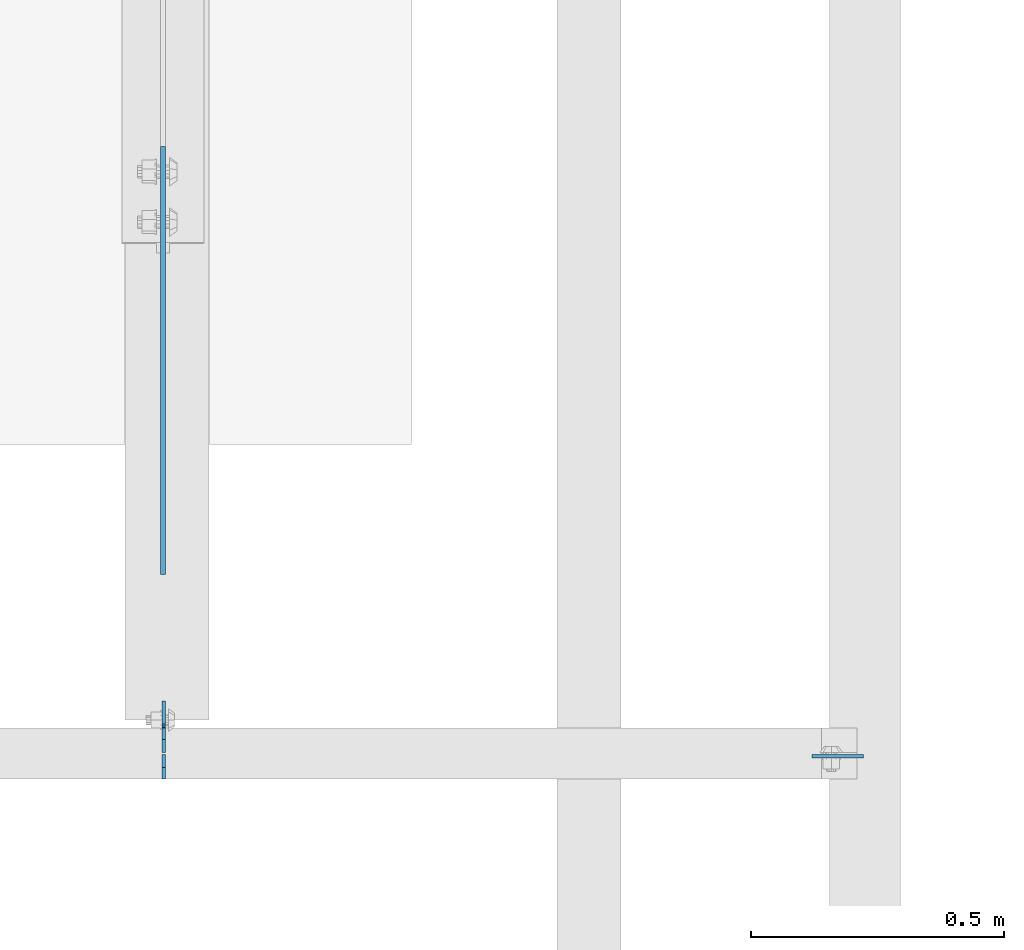
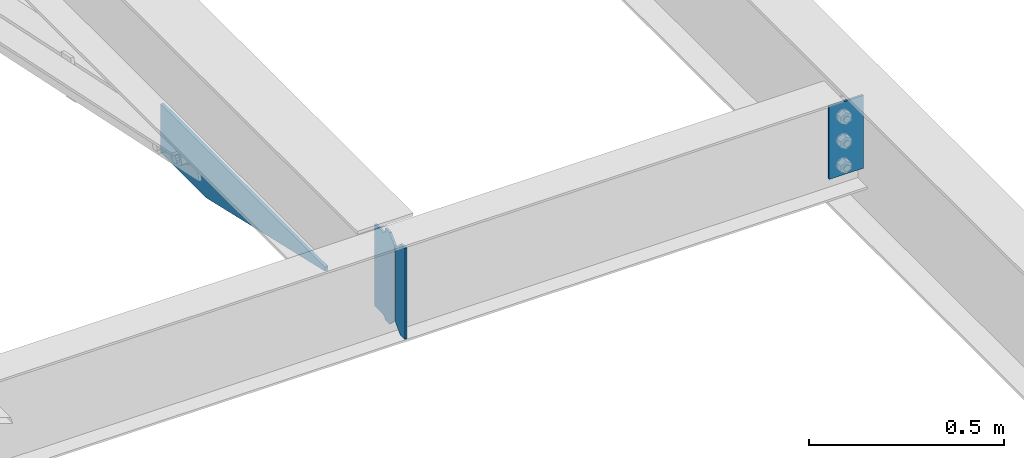
# One storey, part 1607 of 1763: 4 plates, 3 elements without a shape of their own.
"""IFC2X3 building model written with IfcOpenShell, lengths in millimetres."""

import ifcopenshell
import ifcopenshell.guid

model = None  # the IFC model being written
_history = None  # IfcOwnerHistory: only IFC2X3 demands one
_inside = {}  # id of a spatial element -> (the spatial element, [elements in it])
_under = {}  # id of a project, library or spatial element -> (it, [spatial elements below it])
_declared = {}  # id of a project -> (the project, [libraries it declares])
_typed = {}  # id of a type object -> (the type object, [elements of that type])
_made_of = {}  # id of a material, layer set ... -> (it, [elements and type objects made of it])


def new_model(schema):
    """Start an empty IFC model of exactly this schema.

    Asked for "IFC4X3", IfcOpenShell would pick the latest addendum, in which some entities
    have other attributes; the version numbers below select the first issue.
    IFC2X3 requires an IfcOwnerHistory on every rooted entity: one is made here for all.
    """
    global model, _history
    if schema == "IFC4X3":
        model = ifcopenshell.file(schema_version=(4, 3, 0, 0))
    else:
        model = ifcopenshell.file(schema=schema)
    _inside.clear()
    _under.clear()
    _declared.clear()
    _typed.clear()
    _made_of.clear()
    _history = None
    if model.schema == "IFC2X3":
        org = make("IfcOrganization", Name="unknown")
        user = make(
            "IfcPersonAndOrganization",
            ThePerson=make("IfcPerson", FamilyName="unknown"),
            TheOrganization=org,
        )
        app = make(
            "IfcApplication",
            ApplicationDeveloper=org,
            Version="unknown",
            ApplicationFullName="unknown",
            ApplicationIdentifier="unknown",
        )
        _history = make(
            "IfcOwnerHistory",
            OwningUser=user,
            OwningApplication=app,
            ChangeAction="ADDED",
            CreationDate=0,
        )
    return model


def make(cls, **values):
    """One entity of the class cls with the attributes given. An attribute that is None is left unset."""
    return model.create_entity(
        cls, **{name: value for name, value in values.items() if value is not None}
    )


def rooted(cls, **values):
    """An entity with a GlobalId (a new one), such as an element, a storey or a relation."""
    return make(cls, GlobalId=ifcopenshell.guid.new(), OwnerHistory=_history, **values)


def si_unit(unit_type, name, prefix=None):
    """IfcSIUnit, for example si_unit("LENGTHUNIT", "METRE", prefix="MILLI")."""
    return make("IfcSIUnit", UnitType=unit_type, Prefix=prefix, Name=name)


def assignment(units):
    """IfcUnitAssignment: the units of a project."""
    return None if units is None else make("IfcUnitAssignment", Units=units)


def point(xyz):
    """IfcCartesianPoint."""
    return None if xyz is None else make("IfcCartesianPoint", Coordinates=xyz)


def direction(xyz):
    """IfcDirection."""
    return None if xyz is None else make("IfcDirection", DirectionRatios=xyz)


def frame(location, z_axis=None, x_axis=None):
    """IfcAxis2Placement3D, a coordinate frame: its origin and axes. An axis left out is left unset."""
    return make(
        "IfcAxis2Placement3D",
        Location=point(location),
        Axis=direction(z_axis),
        RefDirection=direction(x_axis),
    )


def origin_with_axes():
    """The frame at (0, 0, 0) with the z axis (0, 0, 1) and the x axis (1, 0, 0) written out."""
    return frame((0.0, 0.0, 0.0), z_axis=(0.0, 0.0, 1.0), x_axis=(1.0, 0.0, 0.0))


def place(relative_to, where):
    """IfcLocalPlacement: puts the frame where relative to a parent placement (None: the world)."""
    return make(
        "IfcLocalPlacement", PlacementRelTo=relative_to, RelativePlacement=where
    )


def context(
    kind, dimensions, precision=None, world=None, true_north=None, identifier=None
):
    """IfcGeometricRepresentationContext, for example the 3D "Model" context."""
    return make(
        "IfcGeometricRepresentationContext",
        ContextIdentifier=identifier,
        ContextType=kind,
        CoordinateSpaceDimension=dimensions,
        Precision=precision,
        WorldCoordinateSystem=world,
        TrueNorth=true_north,
    )


def subcontext(parent, identifier, kind, view, scale=None):
    """IfcGeometricRepresentationSubContext, for example "Body" below "Model"."""
    return make(
        "IfcGeometricRepresentationSubContext",
        ContextIdentifier=identifier,
        ContextType=kind,
        ParentContext=parent,
        TargetScale=scale,
        TargetView=view,
    )


def project(units=None, contexts=None):
    """IfcProject with its units and contexts."""
    return rooted(
        "IfcProject",
        Name="project",
        RepresentationContexts=contexts,
        UnitsInContext=assignment(units),
    )


def spatial(cls, under=None, at=None, **own):
    """A site, building, storey or space (cls), placed at a placement, below another one or the project."""
    s = rooted(cls, ObjectPlacement=at, **own)
    if under is not None:
        _under.setdefault(under.id(), (under, []))[1].append(s)
    return s


def faces_of(points, faces, orient=None, outer=None):
    """IfcFace entities. A face is a list of loops; a loop is a list of indices into points, from 0.

    orient and outer hold one flag for each loop. By default every Orientation is true, the
    first loop of a face is its IfcFaceOuterBound and the others are IfcFaceBound.
    """
    made = []
    for i, loops in enumerate(faces):
        bounds = []
        for j, loop in enumerate(loops):
            is_outer = j == 0 if outer is None else outer[i][j]
            bounds.append(
                make(
                    "IfcFaceOuterBound" if is_outer else "IfcFaceBound",
                    Bound=make("IfcPolyLoop", Polygon=[points[k] for k in loop]),
                    Orientation=True if orient is None else orient[i][j],
                )
            )
        made.append(make("IfcFace", Bounds=bounds))
    return made


def faceted_brep(points, faces, orient=None, outer=None, voids=None):
    """IfcFacetedBrep: a solid bounded by flat faces; with voids (closed shells), ...WithVoids."""
    shared = [point(p) for p in points]
    hull = make("IfcClosedShell", CfsFaces=faces_of(shared, faces, orient, outer))
    if voids is None:
        return make("IfcFacetedBrep", Outer=hull)
    return make(
        "IfcFacetedBrepWithVoids",
        Outer=hull,
        Voids=[
            make(cls, CfsFaces=faces_of(shared, fs, o, b)) for cls, fs, o, b in voids
        ],
    )


def shape(context_of_items, identifier, shape_type, items):
    """IfcShapeRepresentation: the items that make up one representation, for example the "Body"."""
    return make(
        "IfcShapeRepresentation",
        ContextOfItems=context_of_items,
        RepresentationIdentifier=identifier,
        RepresentationType=shape_type,
        Items=items,
    )


def material(Name=None, Category=None):
    """IfcMaterial."""
    return make("IfcMaterial", Name=Name, Category=Category)


def made_of(thing, what):
    """Note that an element or type object is made of a material, layer set ...; save() writes the relation."""
    if what is not None:
        _made_of.setdefault(what.id(), (what, []))[1].append(thing)
    return thing


def type_object(cls, material=None, **own):
    """A type object (cls), such as IfcWallType, which elements share."""
    return made_of(rooted(cls, **own), material)


def element(
    cls,
    number,
    at=None,
    inside=None,
    cuts=None,
    type_object=None,
    material=None,
    context=None,
    identifier="Body",
    shape_type=None,
    held_by="IfcProductDefinitionShape",
    body=None,
    shapes=None,
    **own,
):
    """One element of the class cls, such as IfcWall. Its Tag is "e" and its number.

    at: its placement. inside: the storey or other place that contains it. cuts: it is an
    opening in that element (IfcRelVoidsElement). A single representation is given by context,
    identifier, shape_type and body (its items); several are given by shapes. held_by: the class
    of the entity that holds the representations. save() writes the other relations.
    """
    e = rooted(cls, Tag="e%d" % number, ObjectPlacement=at, **own)
    if body is not None:
        shapes = [shape(context, identifier, shape_type, body)]
    if shapes is not None:
        e.Representation = make(held_by, Representations=shapes)
    if inside is not None:
        _inside.setdefault(inside.id(), (inside, []))[1].append(e)
    if cuts is not None:
        rooted(
            "IfcRelVoidsElement", RelatingBuildingElement=cuts, RelatedOpeningElement=e
        )
    if type_object is not None:
        _typed.setdefault(type_object.id(), (type_object, []))[1].append(e)
    return made_of(e, material)


def aggregate(whole, parts):
    """IfcRelAggregates: a whole, such as a stair, and the parts it consists of."""
    return rooted("IfcRelAggregates", RelatingObject=whole, RelatedObjects=parts)


def save(model, path):
    """Write the relations noted so far, then the file.

    IfcRelAggregates (storeys below a building ...), IfcRelContainedInSpatialStructure (elements
    in a storey), IfcRelDefinesByType, IfcRelAssociatesMaterial and IfcRelDeclares: one each for
    every whole, place, type object, material and project.
    """
    for whole, parts in _under.values():
        aggregate(whole, parts)
    for where, things in _inside.values():
        rooted(
            "IfcRelContainedInSpatialStructure",
            RelatedElements=things,
            RelatingStructure=where,
        )
    for kind, things in _typed.values():
        rooted("IfcRelDefinesByType", RelatedObjects=things, RelatingType=kind)
    for what, things in _made_of.values():
        rooted("IfcRelAssociatesMaterial", RelatedObjects=things, RelatingMaterial=what)
    for by, libraries in _declared.values():
        rooted("IfcRelDeclares", RelatingContext=by, RelatedDefinitions=libraries)
    model.write(path)


model = new_model("IFC2X3")

# Units and contexts
model_context = context("Model", 3, precision=1e-05, world=origin_with_axes())
body_context = subcontext(model_context, "Body", "Model", "MODEL_VIEW")
ifc_project = project(units=[si_unit("LENGTHUNIT", "METRE", prefix="MILLI"), si_unit("AREAUNIT", "SQUARE_METRE"), si_unit("VOLUMEUNIT", "CUBIC_METRE"), si_unit("MASSUNIT", "GRAM", prefix="KILO"), si_unit("TIMEUNIT", "SECOND"), si_unit("PLANEANGLEUNIT", "RADIAN"), si_unit("SOLIDANGLEUNIT", "STERADIAN"), si_unit("THERMODYNAMICTEMPERATUREUNIT", "DEGREE_CELSIUS"), si_unit("LUMINOUSINTENSITYUNIT", "LUMEN")], contexts=[model_context])

# Site, building, storey
site_placement = place(None, origin_with_axes())
site = spatial("IfcSite", under=ifc_project, at=site_placement, CompositionType="ELEMENT")
building_placement = place(site_placement, origin_with_axes())
building = spatial("IfcBuilding", under=site, at=building_placement, Name="Undefined", CompositionType="ELEMENT")
storey_placement = place(building_placement, origin_with_axes())
storey = spatial("IfcBuildingStorey", under=building, at=storey_placement, Name="Undefined", CompositionType="ELEMENT", Elevation=0.0)

# Assembly, plate
assembly_1_placement = place(storey_placement, origin_with_axes())
assembly_1 = element("IfcElementAssembly", 1, at=assembly_1_placement, inside=storey, Name="BEAM", AssemblyPlace="NOTDEFINED", PredefinedType="RIGID_FRAME")
ifc_material = material(Name="STEEL/A36")
plate_type_1 = type_object("IfcPlateType", PredefinedType="NOTDEFINED")
plate_1_placement = place(assembly_1_placement, frame((-71152.7747736984, 50880.5595338104, 4883.15), z_axis=(0.0, -1.0, 0.0), x_axis=(0.0, 0.0, -1.0)))
plate_1 = element("IfcPlate", 2, at=plate_1_placement, type_object=plate_type_1, material=ifc_material, Name="PLATE", context=body_context, shape_type="Brep", body=[
    faceted_brep([(0.0, -4.76249999999982, 0.0), (0.0, -4.76249999999709, 844.603210449219), (0.0, 4.76249999999709, 844.603210449219), (0.0, 4.76249999999982, 0.0), (12.6999998092651, -4.76249999999709, 844.603210449219), (12.6999998092651, 4.76249999999709, 844.603210449219), (152.399993896484, -4.76249999999709, 235.00325012207), (152.399993896484, 4.76249999999709, 235.00325012207), (152.400009155272, -4.76249999948777, 5.45696821063757e-12), (152.400009155273, 4.76250000051368, 3.63797880709171e-12)], [[[0, 1, 2, 3]], [[1, 4, 5, 2]], [[4, 6, 7, 5]], [[6, 8, 9, 7]], [[8, 0, 3, 9]], [[5, 7, 9, 3, 2]], [[8, 6, 4, 1, 0]]]),
])
aggregate(assembly_1, [plate_1])

assembly_2_placement = place(storey_placement, origin_with_axes())
assembly_2 = element("IfcElementAssembly", 3, at=assembly_2_placement, inside=storey, Name="BEAM", AssemblyPlace="NOTDEFINED", PredefinedType="RIGID_FRAME")
plate_type_2 = type_object("IfcPlateType", PredefinedType="NOTDEFINED")
plate_2_placement = place(assembly_2_placement, frame((-71151.1872737461, 49684.78125, 4900.6125), z_axis=(0.0, 0.0, 1.0), x_axis=(0.0, 1.0, 0.0)))
plate_2 = element("IfcPlate", 4, at=plate_2_placement, type_object=plate_type_2, material=ifc_material, Name="PLATE", context=body_context, shape_type="Brep", body=[
    faceted_brep([(48.7345236062902, -3.17500000000291, 0.0), (48.7345236062902, 3.17500000000291, 0.0), (49.3854800386544, 3.17500000000291, 3.27257877585271), (49.3854800386544, -3.17500000000291, 3.27257877585271), (52.1384942519726, 3.17500000000291, 7.39275539271512), (52.1384942519726, -3.17500000000291, 7.39275539271512), (56.2586711318072, 3.17500000000291, 10.1457692124714), (56.2586711318072, -3.17500000000291, 10.1457692124714), (61.1187510223899, 3.17500000000291, 11.1124987868779), (61.1187510223899, -3.17500000000291, 11.1124987868779), (101.599998474121, -3.17500000000291, 11.1124949200548), (101.599998474121, 3.17500000000291, 11.1124949200548), (25.3999996184939, -3.17499999996653, 1.2732925824821e-11), (0.0, -3.17499999987194, 25.4000000001051), (0.0, 3.17500000014843, 25.4000000001197), (25.3999996185303, 3.17499995230901, 0.0), (0.0, -3.17500000000291, 261.937494277954), (0.0, 3.17500000000291, 261.937494277954), (25.3999996185303, -3.17500000000291, 287.337493896484), (25.3999996185303, 3.17500000000291, 287.337493896484), (48.4187500000044, -3.17500000000291, 287.337493896484), (48.4187500000044, 3.17500000000291, 287.337493896484), (48.4187500000044, -3.17500000000291, 280.987500572204), (48.4187500000044, 3.17500000000291, 280.987500572204), (49.3854799225956, -3.17500000000291, 276.127421054159), (49.3854799225956, 3.17500000000291, 276.127421054159), (52.1384938230694, -3.17500000000291, 272.007244586005), (52.1384938230694, 3.17500000000291, 272.007244586005), (56.2586702912231, -3.17500000000291, 269.254230685527), (56.2586702912231, 3.17500000000291, 269.254230685527), (61.1187498092695, -3.17500000000291, 268.287500762939), (61.1187498092695, 3.17500000000291, 268.287500762939), (101.599998474121, -3.17500000000291, 268.287500762939), (101.599998474121, 3.17500000000291, 268.287500762939)], [[[0, 1, 2, 3]], [[3, 2, 4, 5]], [[5, 4, 6, 7]], [[7, 6, 8, 9]], [[10, 9, 8, 11]], [[12, 13, 14, 15]], [[13, 16, 17, 14]], [[16, 18, 19, 17]], [[19, 18, 20, 21]], [[20, 22, 23, 21]], [[24, 25, 23, 22]], [[26, 27, 25, 24]], [[28, 29, 27, 26]], [[30, 31, 29, 28]], [[32, 33, 31, 30]], [[33, 32, 10, 11]], [[6, 4, 2, 1, 15, 14, 17, 19, 21, 23, 25, 27, 29, 31, 33, 11, 8]], [[12, 15, 1, 0]], [[32, 30, 28, 26, 24, 22, 20, 18, 16, 13, 12, 0, 3, 5, 7, 9, 10]]]),
])

assembly_3_placement = place(storey_placement, origin_with_axes())
assembly_3 = element("IfcElementAssembly", 5, at=assembly_3_placement, inside=storey, Name="BEAM", AssemblyPlace="NOTDEFINED", PredefinedType="RIGID_FRAME")
plate_3_placement = place(assembly_3_placement, frame((-69770.0622736983, 49676.84375, 5156.2), z_axis=(-1.0, 0.0, 0.0), x_axis=(0.0, 0.0, -1.0)))
plate_3 = element("IfcPlate", 6, at=plate_3_placement, type_object=plate_type_2, material=ifc_material, Name="PLATE", context=body_context, shape_type="Brep", body=[
    faceted_brep([(1.81898940354586e-12, -3.17500000000291, 0.0), (0.0, -3.17499999999927, 101.599998474121), (0.0, 3.17499999999927, 101.599998474121), (-1.81898940354586e-12, 3.17499999997381, 0.0), (228.600006103516, -3.17499999999927, 101.599998474121), (228.600006103516, 3.17499999999927, 101.599998474121), (228.600006103516, -3.17500000001019, -7.27595761418343e-12), (228.600006103516, 3.17499999999563, -7.27595761418343e-12)], [[[0, 1, 2, 3]], [[1, 4, 5, 2]], [[4, 6, 7, 5]], [[6, 0, 3, 7]], [[5, 7, 3, 2]], [[6, 4, 1, 0]]]),
])
aggregate(assembly_3, [plate_3])

# Plate
plate_type_3 = type_object("IfcPlateType", PredefinedType="NOTDEFINED")
plate_4_placement = place(assembly_2_placement, frame((-71151.187273746, 49680.01875, 4900.6125), z_axis=(0.0, 0.0, 1.0), x_axis=(0.0, -1.0, 0.0)))
plate_4 = element("IfcPlate", 7, at=plate_4_placement, type_object=plate_type_3, material=ifc_material, Name="PLATE", context=body_context, shape_type="Brep", body=[
    faceted_brep([(0.0, -3.17499999987194, 25.4000000001051), (0.0, -3.17500000000291, 260.35000038147), (0.0, 3.17500000000291, 260.35000038147), (0.0, 3.17500000014843, 25.4000000001197), (25.3999996185303, -3.17500000000291, 285.75), (25.3999996185303, 3.17500000000291, 285.75), (48.4187507629395, -3.17500000000291, 285.75), (48.4187507629395, 3.17500000000291, 285.75), (48.4187507629395, -3.17500000000291, 0.0), (48.4187507629395, 3.17500000000291, 0.0), (25.3999996184939, -3.17499999996653, 1.2732925824821e-11), (25.3999996185303, 3.17499995230901, 0.0)], [[[0, 1, 2, 3]], [[1, 4, 5, 2]], [[4, 6, 7, 5]], [[6, 8, 9, 7]], [[8, 10, 11, 9]], [[10, 0, 3, 11]], [[5, 7, 9, 11, 3, 2]], [[10, 8, 6, 4, 1, 0]]]),
])

aggregate(assembly_2, [plate_4, plate_2])

save(model, "model.ifc")
